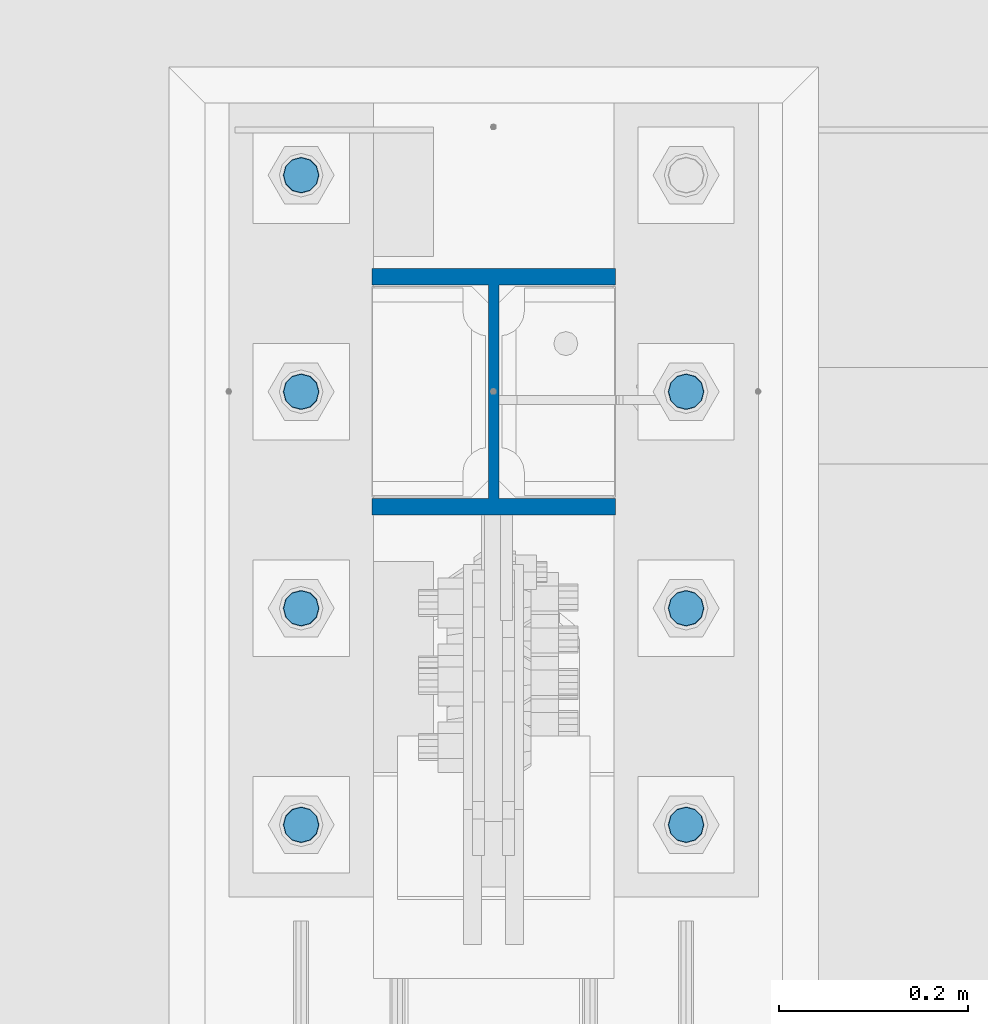
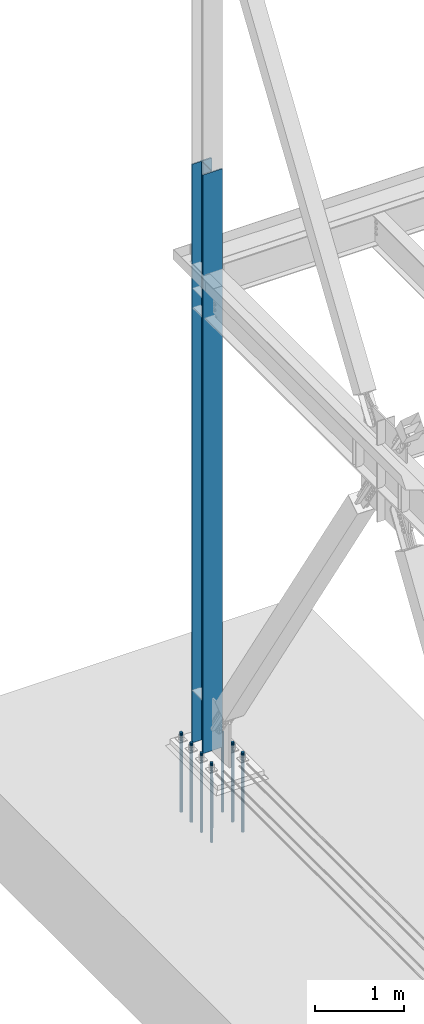
# One storey, part 1349 of 3843: 8 columns, 2 elements without a shape of their own.
"""IFC2X3 building model written with IfcOpenShell, lengths in millimetres."""

from ifc_helpers import new_model, si_unit, frame, origin_with_axes, place, context, subcontext, project, spatial, faceted_brep, material, type_object, element, aggregate, save


model = new_model("IFC2X3")

# Units and contexts
model_context = context("Model", 3, precision=1e-05, world=origin_with_axes())
body_context = subcontext(model_context, "Body", "Model", "MODEL_VIEW")
ifc_project = project(units=[si_unit("LENGTHUNIT", "METRE", prefix="MILLI"), si_unit("AREAUNIT", "SQUARE_METRE"), si_unit("VOLUMEUNIT", "CUBIC_METRE"), si_unit("MASSUNIT", "GRAM", prefix="KILO"), si_unit("TIMEUNIT", "SECOND"), si_unit("PLANEANGLEUNIT", "RADIAN"), si_unit("SOLIDANGLEUNIT", "STERADIAN"), si_unit("THERMODYNAMICTEMPERATUREUNIT", "DEGREE_CELSIUS"), si_unit("LUMINOUSINTENSITYUNIT", "LUMEN")], contexts=[model_context])

# Site, building, storey
site_placement = place(None, origin_with_axes())
site = spatial("IfcSite", under=ifc_project, at=site_placement, CompositionType="ELEMENT")
building_placement = place(site_placement, origin_with_axes())
building = spatial("IfcBuilding", under=site, at=building_placement, Name="Undefined", CompositionType="ELEMENT")
storey_placement = place(building_placement, origin_with_axes())
storey = spatial("IfcBuildingStorey", under=building, at=storey_placement, Name="Undefined", CompositionType="ELEMENT", Elevation=0.0)

# Assembly, column
assembly_1_placement = place(storey_placement, origin_with_axes())
assembly_1 = element("IfcElementAssembly", 1, at=assembly_1_placement, inside=storey, Name="COLUMN", AssemblyPlace="NOTDEFINED", PredefinedType="RIGID_FRAME")
ifc_material_1 = material(Name="STEEL/A992")
column_type_1 = type_object("IfcColumnType", Name="W10X60", PredefinedType="NOTDEFINED")
column_1_placement = place(assembly_1_placement, frame((0.0, 104559.1, 29718.0), z_axis=(0.0, 1.0, 0.0), x_axis=(0.0, 0.0, 1.0)))
column_1 = element("IfcColumn", 2, at=column_1_placement, type_object=column_type_1, material=ifc_material_1, Name="COLUMN", ObjectType="W10X60", context=body_context, shape_type="Brep", body=[
    faceted_brep([(101.599999999999, 128.587499999994, -130.174999999999), (101.599999999999, 128.587499999994, -112.712500000001), (8077.2, 128.5875, -112.712499999994), (8077.2, 128.5875, -130.175000000003), (101.599999999999, 5.55624999999418, -112.712500000001), (8077.2, 5.55625, -112.712499999994), (101.599999999999, 5.55624999999418, 112.712500000001), (8077.2, 5.55625, 112.712499999994), (101.599999999999, 128.587499999994, 112.712500000001), (8077.2, 128.5875, 112.712499999994), (101.599999999999, 128.587499999994, 130.174999999999), (8077.2, 128.5875, 130.175000000003), (101.599999999999, -128.587499999994, 130.174999999999), (8077.2, -128.5875, 130.175000000003), (101.599999999999, -128.587499999994, 112.712500000001), (8077.2, -128.5875, 112.712499999994), (101.599999999999, -5.55624999999418, 112.712500000001), (8077.2, -5.55625, 112.712499999994), (101.599999999999, -5.55624999999418, -112.712500000001), (8077.2, -5.55625, -112.712499999994), (101.599999999999, -128.587499999994, -112.712500000001), (8077.2, -128.5875, -112.712499999994), (101.599999999999, -128.587499999994, -130.174999999999), (8077.2, -128.5875, -130.175000000003)], [[[0, 1, 2, 3]], [[1, 4, 5, 2]], [[4, 6, 7, 5]], [[6, 8, 9, 7]], [[8, 10, 11, 9]], [[10, 12, 13, 11]], [[12, 14, 15, 13]], [[14, 16, 17, 15]], [[16, 18, 19, 17]], [[18, 20, 21, 19]], [[20, 22, 23, 21]], [[22, 0, 3, 23]], [[5, 7, 9, 11, 13, 15, 17, 19, 21, 23, 3, 2]], [[22, 20, 18, 16, 14, 12, 10, 8, 6, 4, 1, 0]]]),
])
aggregate(assembly_1, [column_1])

# Assembly, columns
assembly_2_placement = place(storey_placement, origin_with_axes())
assembly_2 = element("IfcElementAssembly", 3, at=assembly_2_placement, inside=storey, Name="TEMPLATE", AssemblyPlace="NOTDEFINED", PredefinedType="RIGID_FRAME")
ifc_material_2 = material(Name="Undefined/F1554-GR.55")
column_type_2 = type_object("IfcColumnType", PredefinedType="NOTDEFINED")
column_2_placement = place(assembly_2_placement, frame((-203.2, 104101.9, 29718.0), z_axis=(0.0, -1.0, 0.0), x_axis=(0.0, 0.0, -1.0)))
column_2 = element("IfcColumn", 4, at=column_2_placement, type_object=column_type_2, material=ifc_material_2, Name="ANCHOR_ROD", context=body_context, shape_type="Brep", body=[
    faceted_brep([(-209.549999999999, -16.0214699700155, 9.25), (-209.549999999999, -9.25, 16.0214699700118), (-209.549999999999, 0.0, 18.5), (-209.549999999999, 9.25, 16.0214699700118), (-209.549999999999, 16.0214699700155, 9.25), (-209.549999999999, 18.5, 0.0), (-209.549999999999, 16.0214699700155, -9.25), (-209.549999999999, 9.25, -16.0214699700118), (-209.549999999999, 0.0, -18.5), (-209.549999999999, -9.25, -16.0214699700118), (-209.549999999999, -16.0214699700155, -9.25), (-209.549999999999, -18.5, 0.0), (0.0, 18.5, 0.0), (0.0, 16.0214699700118, -9.25), (0.0, 9.25, -16.0214699700155), (0.0, 0.0, -18.5), (0.0, -9.25, -16.0214699700155), (0.0, -16.0214699700118, -9.25), (0.0, -18.5, 0.0), (0.0, -16.0214699700118, 9.25), (0.0, -9.25, 16.0214699700155), (0.0, 0.0, 18.5), (0.0, 9.25, 16.0214699700155), (0.0, 16.0214699700118, 9.25), (0.0, -16.4977839420972, 9.52500000000146), (0.0, -9.52500000000146, 16.4977839420972), (0.0, 0.0, 19.0499989999989), (0.0, 9.52500000000146, 16.4977839420972), (0.0, 16.4977839420972, 9.52500000000146), (0.0, 19.0500000000029, 0.0), (0.0, 16.4977839420972, -9.52500000000146), (0.0, 9.52500000000146, -16.4977839420972), (0.0, 0.0, -19.0499989999989), (0.0, -9.52500000000146, -16.4977839420972), (0.0, -16.4977839420972, -9.52500000000146), (0.0, -19.0500000000029, 0.0), (698.5, -19.0499999999993, 0.0), (698.5, -16.4977839420935, 9.52499999999418), (698.5, -9.52500000000146, 16.4977839420899), (698.5, 0.0, 19.0500000000029), (698.5, 9.52500000000146, 16.4977839420899), (698.5, 16.4977839420935, 9.52499999999418), (698.5, 19.0499999999993, 0.0), (698.5, 16.4977839420935, -9.52499999999418), (698.5, 9.52500000000146, -16.4977839420899), (698.5, 0.0, -19.0500000000029), (698.5, -9.52500000000146, -16.4977839420899), (698.5, -16.4977839420935, -9.52499999999418), (698.5, -9.25, 16.0214699700155), (698.5, 0.0, 18.5), (698.5, 9.25, 16.0214699700155), (698.5, 16.0214699700118, 9.25), (698.5, 18.5, 0.0), (698.5, 16.0214699700118, -9.25), (698.5, 9.25, -16.0214699700155), (698.5, 0.0, -18.5), (698.5, -9.25, -16.0214699700155), (698.5, -16.0214699700118, -9.25), (698.5, -18.5, 0.0), (698.5, -16.0214699700118, 9.25), (889.0, -9.25, -16.0214699700155), (889.0, 0.0, -18.5), (889.0, 9.25, -16.0214699700155), (889.0, 16.0214699700118, -9.25), (889.0, 18.5, 0.0), (889.0, 16.0214699700118, 9.25), (889.0, 9.25, 16.0214699700155), (889.0, 0.0, 18.5), (889.0, -9.25, 16.0214699700155), (889.0, -16.0214699700118, 9.25), (889.0, -18.5, 0.0), (889.0, -16.0214699700118, -9.25)], [[[0, 1, 2, 3, 4, 5, 6, 7, 8, 9, 10, 11]], [[6, 5, 12, 13]], [[7, 6, 13, 14]], [[8, 7, 14, 15]], [[9, 8, 15, 16]], [[10, 9, 16, 17]], [[11, 10, 17, 18]], [[0, 11, 18, 19]], [[1, 0, 19, 20]], [[2, 1, 20, 21]], [[3, 2, 21, 22]], [[4, 3, 22, 23]], [[5, 4, 23, 12]], [[24, 25, 26, 27, 28, 29, 30, 31, 32, 33, 34, 35], [22, 21, 20, 19, 18, 17, 16, 15, 14, 13, 12, 23]], [[24, 35, 36, 37]], [[25, 24, 37, 38]], [[26, 25, 38, 39]], [[27, 26, 39, 40]], [[28, 27, 40, 41]], [[29, 28, 41, 42]], [[30, 29, 42, 43]], [[31, 30, 43, 44]], [[32, 31, 44, 45]], [[33, 32, 45, 46]], [[34, 33, 46, 47]], [[35, 34, 47, 36]], [[46, 45, 44, 43, 42, 41, 40, 39, 38, 37, 36, 47], [48, 49, 50, 51, 52, 53, 54, 55, 56, 57, 58, 59]], [[60, 61, 62, 63, 64, 65, 66, 67, 68, 69, 70, 71]], [[68, 67, 49, 48]], [[69, 68, 48, 59]], [[70, 69, 59, 58]], [[71, 70, 58, 57]], [[60, 71, 57, 56]], [[61, 60, 56, 55]], [[62, 61, 55, 54]], [[63, 62, 54, 53]], [[64, 63, 53, 52]], [[65, 64, 52, 51]], [[66, 65, 51, 50]], [[67, 66, 50, 49]]]),
])
column_3_placement = place(assembly_2_placement, frame((203.2, 104101.9, 29718.0), z_axis=(0.0, 1.0, 0.0), x_axis=(0.0, 0.0, -1.0)))
column_3 = element("IfcColumn", 5, at=column_3_placement, type_object=column_type_2, material=ifc_material_2, Name="ANCHOR_ROD", context=body_context, shape_type="Brep", body=[
    faceted_brep([(-209.549999999999, -16.0214699700155, 9.25), (-209.549999999999, -9.25, 16.0214699700118), (-209.549999999999, 0.0, 18.5), (-209.549999999999, 9.25, 16.0214699700118), (-209.549999999999, 16.0214699700155, 9.25), (-209.549999999999, 18.5, 0.0), (-209.549999999999, 16.0214699700155, -9.25), (-209.549999999999, 9.25, -16.0214699700118), (-209.549999999999, 0.0, -18.5), (-209.549999999999, -9.25, -16.0214699700118), (-209.549999999999, -16.0214699700155, -9.25), (-209.549999999999, -18.5, 0.0), (0.0, 18.5, 0.0), (0.0, 16.0214699700118, -9.25), (0.0, 9.25, -16.0214699700155), (0.0, 0.0, -18.5), (0.0, -9.25, -16.0214699700155), (0.0, -16.0214699700118, -9.25), (0.0, -18.5, 0.0), (0.0, -16.0214699700118, 9.25), (0.0, -9.25, 16.0214699700155), (0.0, 0.0, 18.5), (0.0, 9.25, 16.0214699700155), (0.0, 16.0214699700118, 9.25), (0.0, -16.4977839420972, 9.52500000000146), (0.0, -9.52500000000146, 16.4977839420972), (0.0, 0.0, 19.0499989999989), (0.0, 9.52500000000146, 16.4977839420972), (0.0, 16.4977839420972, 9.52500000000146), (0.0, 19.0500000000029, 0.0), (0.0, 16.4977839420972, -9.52500000000146), (0.0, 9.52500000000146, -16.4977839420972), (0.0, 0.0, -19.0499989999989), (0.0, -9.52500000000146, -16.4977839420972), (0.0, -16.4977839420972, -9.52500000000146), (0.0, -19.0500000000029, 0.0), (698.5, -19.0499999999993, 0.0), (698.5, -16.4977839420935, 9.52499999999418), (698.5, -9.52500000000146, 16.4977839420899), (698.5, 0.0, 19.0500000000029), (698.5, 9.52500000000146, 16.4977839420899), (698.5, 16.4977839420935, 9.52499999999418), (698.5, 19.0499999999993, 0.0), (698.5, 16.4977839420935, -9.52499999999418), (698.5, 9.52500000000146, -16.4977839420899), (698.5, 0.0, -19.0500000000029), (698.5, -9.52500000000146, -16.4977839420899), (698.5, -16.4977839420935, -9.52499999999418), (698.5, -9.25, 16.0214699700155), (698.5, 0.0, 18.5), (698.5, 9.25, 16.0214699700155), (698.5, 16.0214699700118, 9.25), (698.5, 18.5, 0.0), (698.5, 16.0214699700118, -9.25), (698.5, 9.25, -16.0214699700155), (698.5, 0.0, -18.5), (698.5, -9.25, -16.0214699700155), (698.5, -16.0214699700118, -9.25), (698.5, -18.5, 0.0), (698.5, -16.0214699700118, 9.25), (889.0, -9.25, -16.0214699700155), (889.0, 0.0, -18.5), (889.0, 9.25, -16.0214699700155), (889.0, 16.0214699700118, -9.25), (889.0, 18.5, 0.0), (889.0, 16.0214699700118, 9.25), (889.0, 9.25, 16.0214699700155), (889.0, 0.0, 18.5), (889.0, -9.25, 16.0214699700155), (889.0, -16.0214699700118, 9.25), (889.0, -18.5, 0.0), (889.0, -16.0214699700118, -9.25)], [[[0, 1, 2, 3, 4, 5, 6, 7, 8, 9, 10, 11]], [[6, 5, 12, 13]], [[7, 6, 13, 14]], [[8, 7, 14, 15]], [[9, 8, 15, 16]], [[10, 9, 16, 17]], [[11, 10, 17, 18]], [[0, 11, 18, 19]], [[1, 0, 19, 20]], [[2, 1, 20, 21]], [[3, 2, 21, 22]], [[4, 3, 22, 23]], [[5, 4, 23, 12]], [[24, 25, 26, 27, 28, 29, 30, 31, 32, 33, 34, 35], [22, 21, 20, 19, 18, 17, 16, 15, 14, 13, 12, 23]], [[24, 35, 36, 37]], [[25, 24, 37, 38]], [[26, 25, 38, 39]], [[27, 26, 39, 40]], [[28, 27, 40, 41]], [[29, 28, 41, 42]], [[30, 29, 42, 43]], [[31, 30, 43, 44]], [[32, 31, 44, 45]], [[33, 32, 45, 46]], [[34, 33, 46, 47]], [[35, 34, 47, 36]], [[46, 45, 44, 43, 42, 41, 40, 39, 38, 37, 36, 47], [48, 49, 50, 51, 52, 53, 54, 55, 56, 57, 58, 59]], [[60, 61, 62, 63, 64, 65, 66, 67, 68, 69, 70, 71]], [[68, 67, 49, 48]], [[69, 68, 48, 59]], [[70, 69, 59, 58]], [[71, 70, 58, 57]], [[60, 71, 57, 56]], [[61, 60, 56, 55]], [[62, 61, 55, 54]], [[63, 62, 54, 53]], [[64, 63, 53, 52]], [[65, 64, 52, 51]], [[66, 65, 51, 50]], [[67, 66, 50, 49]]]),
])
column_4_placement = place(assembly_2_placement, frame((-203.2, 104330.5, 29718.0), z_axis=(0.0, -1.0, 0.0), x_axis=(0.0, 0.0, -1.0)))
column_4 = element("IfcColumn", 6, at=column_4_placement, type_object=column_type_2, material=ifc_material_2, Name="ANCHOR_ROD", context=body_context, shape_type="Brep", body=[
    faceted_brep([(-209.549999999999, -16.0214699700155, 9.25), (-209.549999999999, -9.25, 16.0214699700118), (-209.549999999999, 0.0, 18.5), (-209.549999999999, 9.25, 16.0214699700118), (-209.549999999999, 16.0214699700155, 9.25), (-209.549999999999, 18.5, 0.0), (-209.549999999999, 16.0214699700155, -9.25), (-209.549999999999, 9.25, -16.0214699700118), (-209.549999999999, 0.0, -18.5), (-209.549999999999, -9.25, -16.0214699700118), (-209.549999999999, -16.0214699700155, -9.25), (-209.549999999999, -18.5, 0.0), (0.0, 18.5, 0.0), (0.0, 16.0214699700118, -9.25), (0.0, 9.25, -16.0214699700155), (0.0, 0.0, -18.5), (0.0, -9.25, -16.0214699700155), (0.0, -16.0214699700118, -9.25), (0.0, -18.5, 0.0), (0.0, -16.0214699700118, 9.25), (0.0, -9.25, 16.0214699700155), (0.0, 0.0, 18.5), (0.0, 9.25, 16.0214699700155), (0.0, 16.0214699700118, 9.25), (0.0, -16.4977839420972, 9.52500000000146), (0.0, -9.52500000000146, 16.4977839420972), (0.0, 0.0, 19.0499989999989), (0.0, 9.52500000000146, 16.4977839420972), (0.0, 16.4977839420972, 9.52500000000146), (0.0, 19.0500000000029, 0.0), (0.0, 16.4977839420972, -9.52500000000146), (0.0, 9.52500000000146, -16.4977839420972), (0.0, 0.0, -19.0499989999989), (0.0, -9.52500000000146, -16.4977839420972), (0.0, -16.4977839420972, -9.52500000000146), (0.0, -19.0500000000029, 0.0), (698.5, -19.0499999999993, 0.0), (698.5, -16.4977839420935, 9.52499999999418), (698.5, -9.52500000000146, 16.4977839420899), (698.5, 0.0, 19.0500000000029), (698.5, 9.52500000000146, 16.4977839420899), (698.5, 16.4977839420935, 9.52499999999418), (698.5, 19.0499999999993, 0.0), (698.5, 16.4977839420935, -9.52499999999418), (698.5, 9.52500000000146, -16.4977839420899), (698.5, 0.0, -19.0500000000029), (698.5, -9.52500000000146, -16.4977839420899), (698.5, -16.4977839420935, -9.52499999999418), (698.5, -9.25, 16.0214699700155), (698.5, 0.0, 18.5), (698.5, 9.25, 16.0214699700155), (698.5, 16.0214699700118, 9.25), (698.5, 18.5, 0.0), (698.5, 16.0214699700118, -9.25), (698.5, 9.25, -16.0214699700155), (698.5, 0.0, -18.5), (698.5, -9.25, -16.0214699700155), (698.5, -16.0214699700118, -9.25), (698.5, -18.5, 0.0), (698.5, -16.0214699700118, 9.25), (889.0, -9.25, -16.0214699700155), (889.0, 0.0, -18.5), (889.0, 9.25, -16.0214699700155), (889.0, 16.0214699700118, -9.25), (889.0, 18.5, 0.0), (889.0, 16.0214699700118, 9.25), (889.0, 9.25, 16.0214699700155), (889.0, 0.0, 18.5), (889.0, -9.25, 16.0214699700155), (889.0, -16.0214699700118, 9.25), (889.0, -18.5, 0.0), (889.0, -16.0214699700118, -9.25)], [[[0, 1, 2, 3, 4, 5, 6, 7, 8, 9, 10, 11]], [[6, 5, 12, 13]], [[7, 6, 13, 14]], [[8, 7, 14, 15]], [[9, 8, 15, 16]], [[10, 9, 16, 17]], [[11, 10, 17, 18]], [[0, 11, 18, 19]], [[1, 0, 19, 20]], [[2, 1, 20, 21]], [[3, 2, 21, 22]], [[4, 3, 22, 23]], [[5, 4, 23, 12]], [[24, 25, 26, 27, 28, 29, 30, 31, 32, 33, 34, 35], [22, 21, 20, 19, 18, 17, 16, 15, 14, 13, 12, 23]], [[24, 35, 36, 37]], [[25, 24, 37, 38]], [[26, 25, 38, 39]], [[27, 26, 39, 40]], [[28, 27, 40, 41]], [[29, 28, 41, 42]], [[30, 29, 42, 43]], [[31, 30, 43, 44]], [[32, 31, 44, 45]], [[33, 32, 45, 46]], [[34, 33, 46, 47]], [[35, 34, 47, 36]], [[46, 45, 44, 43, 42, 41, 40, 39, 38, 37, 36, 47], [48, 49, 50, 51, 52, 53, 54, 55, 56, 57, 58, 59]], [[60, 61, 62, 63, 64, 65, 66, 67, 68, 69, 70, 71]], [[68, 67, 49, 48]], [[69, 68, 48, 59]], [[70, 69, 59, 58]], [[71, 70, 58, 57]], [[60, 71, 57, 56]], [[61, 60, 56, 55]], [[62, 61, 55, 54]], [[63, 62, 54, 53]], [[64, 63, 53, 52]], [[65, 64, 52, 51]], [[66, 65, 51, 50]], [[67, 66, 50, 49]]]),
])
column_5_placement = place(assembly_2_placement, frame((203.2, 104330.5, 29718.0), z_axis=(0.0, 1.0, 0.0), x_axis=(0.0, 0.0, -1.0)))
column_5 = element("IfcColumn", 7, at=column_5_placement, type_object=column_type_2, material=ifc_material_2, Name="ANCHOR_ROD", context=body_context, shape_type="Brep", body=[
    faceted_brep([(-209.549999999999, -16.0214699700155, 9.25), (-209.549999999999, -9.25, 16.0214699700118), (-209.549999999999, 0.0, 18.5), (-209.549999999999, 9.25, 16.0214699700118), (-209.549999999999, 16.0214699700155, 9.25), (-209.549999999999, 18.5, 0.0), (-209.549999999999, 16.0214699700155, -9.25), (-209.549999999999, 9.25, -16.0214699700118), (-209.549999999999, 0.0, -18.5), (-209.549999999999, -9.25, -16.0214699700118), (-209.549999999999, -16.0214699700155, -9.25), (-209.549999999999, -18.5, 0.0), (0.0, 18.5, 0.0), (0.0, 16.0214699700118, -9.25), (0.0, 9.25, -16.0214699700155), (0.0, 0.0, -18.5), (0.0, -9.25, -16.0214699700155), (0.0, -16.0214699700118, -9.25), (0.0, -18.5, 0.0), (0.0, -16.0214699700118, 9.25), (0.0, -9.25, 16.0214699700155), (0.0, 0.0, 18.5), (0.0, 9.25, 16.0214699700155), (0.0, 16.0214699700118, 9.25), (0.0, -16.4977839420972, 9.52500000000146), (0.0, -9.52500000000146, 16.4977839420972), (0.0, 0.0, 19.0499989999989), (0.0, 9.52500000000146, 16.4977839420972), (0.0, 16.4977839420972, 9.52500000000146), (0.0, 19.0500000000029, 0.0), (0.0, 16.4977839420972, -9.52500000000146), (0.0, 9.52500000000146, -16.4977839420972), (0.0, 0.0, -19.0499989999989), (0.0, -9.52500000000146, -16.4977839420972), (0.0, -16.4977839420972, -9.52500000000146), (0.0, -19.0500000000029, 0.0), (698.5, -19.0499999999993, 0.0), (698.5, -16.4977839420935, 9.52499999999418), (698.5, -9.52500000000146, 16.4977839420899), (698.5, 0.0, 19.0500000000029), (698.5, 9.52500000000146, 16.4977839420899), (698.5, 16.4977839420935, 9.52499999999418), (698.5, 19.0499999999993, 0.0), (698.5, 16.4977839420935, -9.52499999999418), (698.5, 9.52500000000146, -16.4977839420899), (698.5, 0.0, -19.0500000000029), (698.5, -9.52500000000146, -16.4977839420899), (698.5, -16.4977839420935, -9.52499999999418), (698.5, -9.25, 16.0214699700155), (698.5, 0.0, 18.5), (698.5, 9.25, 16.0214699700155), (698.5, 16.0214699700118, 9.25), (698.5, 18.5, 0.0), (698.5, 16.0214699700118, -9.25), (698.5, 9.25, -16.0214699700155), (698.5, 0.0, -18.5), (698.5, -9.25, -16.0214699700155), (698.5, -16.0214699700118, -9.25), (698.5, -18.5, 0.0), (698.5, -16.0214699700118, 9.25), (889.0, -9.25, -16.0214699700155), (889.0, 0.0, -18.5), (889.0, 9.25, -16.0214699700155), (889.0, 16.0214699700118, -9.25), (889.0, 18.5, 0.0), (889.0, 16.0214699700118, 9.25), (889.0, 9.25, 16.0214699700155), (889.0, 0.0, 18.5), (889.0, -9.25, 16.0214699700155), (889.0, -16.0214699700118, 9.25), (889.0, -18.5, 0.0), (889.0, -16.0214699700118, -9.25)], [[[0, 1, 2, 3, 4, 5, 6, 7, 8, 9, 10, 11]], [[6, 5, 12, 13]], [[7, 6, 13, 14]], [[8, 7, 14, 15]], [[9, 8, 15, 16]], [[10, 9, 16, 17]], [[11, 10, 17, 18]], [[0, 11, 18, 19]], [[1, 0, 19, 20]], [[2, 1, 20, 21]], [[3, 2, 21, 22]], [[4, 3, 22, 23]], [[5, 4, 23, 12]], [[24, 25, 26, 27, 28, 29, 30, 31, 32, 33, 34, 35], [22, 21, 20, 19, 18, 17, 16, 15, 14, 13, 12, 23]], [[24, 35, 36, 37]], [[25, 24, 37, 38]], [[26, 25, 38, 39]], [[27, 26, 39, 40]], [[28, 27, 40, 41]], [[29, 28, 41, 42]], [[30, 29, 42, 43]], [[31, 30, 43, 44]], [[32, 31, 44, 45]], [[33, 32, 45, 46]], [[34, 33, 46, 47]], [[35, 34, 47, 36]], [[46, 45, 44, 43, 42, 41, 40, 39, 38, 37, 36, 47], [48, 49, 50, 51, 52, 53, 54, 55, 56, 57, 58, 59]], [[60, 61, 62, 63, 64, 65, 66, 67, 68, 69, 70, 71]], [[68, 67, 49, 48]], [[69, 68, 48, 59]], [[70, 69, 59, 58]], [[71, 70, 58, 57]], [[60, 71, 57, 56]], [[61, 60, 56, 55]], [[62, 61, 55, 54]], [[63, 62, 54, 53]], [[64, 63, 53, 52]], [[65, 64, 52, 51]], [[66, 65, 51, 50]], [[67, 66, 50, 49]]]),
])
column_6_placement = place(assembly_2_placement, frame((-203.2, 104559.1, 29718.0), z_axis=(0.0, -1.0, 0.0), x_axis=(0.0, 0.0, -1.0)))
column_6 = element("IfcColumn", 8, at=column_6_placement, type_object=column_type_2, material=ifc_material_2, Name="ANCHOR_ROD", context=body_context, shape_type="Brep", body=[
    faceted_brep([(-209.549999999999, -16.0214699700155, 9.25), (-209.549999999999, -9.25, 16.0214699700118), (-209.549999999999, 0.0, 18.5), (-209.549999999999, 9.25, 16.0214699700118), (-209.549999999999, 16.0214699700155, 9.25), (-209.549999999999, 18.5, 0.0), (-209.549999999999, 16.0214699700155, -9.25), (-209.549999999999, 9.25, -16.0214699700118), (-209.549999999999, 0.0, -18.5), (-209.549999999999, -9.25, -16.0214699700118), (-209.549999999999, -16.0214699700155, -9.25), (-209.549999999999, -18.5, 0.0), (0.0, 18.5, 0.0), (0.0, 16.0214699700118, -9.25), (0.0, 9.25, -16.0214699700155), (0.0, 0.0, -18.5), (0.0, -9.25, -16.0214699700155), (0.0, -16.0214699700118, -9.25), (0.0, -18.5, 0.0), (0.0, -16.0214699700118, 9.25), (0.0, -9.25, 16.0214699700155), (0.0, 0.0, 18.5), (0.0, 9.25, 16.0214699700155), (0.0, 16.0214699700118, 9.25), (0.0, -16.4977839420972, 9.52500000000146), (0.0, -9.52500000000146, 16.4977839420972), (0.0, 0.0, 19.0499989999989), (0.0, 9.52500000000146, 16.4977839420972), (0.0, 16.4977839420972, 9.52500000000146), (0.0, 19.0500000000029, 0.0), (0.0, 16.4977839420972, -9.52500000000146), (0.0, 9.52500000000146, -16.4977839420972), (0.0, 0.0, -19.0499989999989), (0.0, -9.52500000000146, -16.4977839420972), (0.0, -16.4977839420972, -9.52500000000146), (0.0, -19.0500000000029, 0.0), (698.5, -19.0499999999993, 0.0), (698.5, -16.4977839420935, 9.52499999999418), (698.5, -9.52500000000146, 16.4977839420899), (698.5, 0.0, 19.0500000000029), (698.5, 9.52500000000146, 16.4977839420899), (698.5, 16.4977839420935, 9.52499999999418), (698.5, 19.0499999999993, 0.0), (698.5, 16.4977839420935, -9.52499999999418), (698.5, 9.52500000000146, -16.4977839420899), (698.5, 0.0, -19.0500000000029), (698.5, -9.52500000000146, -16.4977839420899), (698.5, -16.4977839420935, -9.52499999999418), (698.5, -9.25, 16.0214699700155), (698.5, 0.0, 18.5), (698.5, 9.25, 16.0214699700155), (698.5, 16.0214699700118, 9.25), (698.5, 18.5, 0.0), (698.5, 16.0214699700118, -9.25), (698.5, 9.25, -16.0214699700155), (698.5, 0.0, -18.5), (698.5, -9.25, -16.0214699700155), (698.5, -16.0214699700118, -9.25), (698.5, -18.5, 0.0), (698.5, -16.0214699700118, 9.25), (889.0, -9.25, -16.0214699700155), (889.0, 0.0, -18.5), (889.0, 9.25, -16.0214699700155), (889.0, 16.0214699700118, -9.25), (889.0, 18.5, 0.0), (889.0, 16.0214699700118, 9.25), (889.0, 9.25, 16.0214699700155), (889.0, 0.0, 18.5), (889.0, -9.25, 16.0214699700155), (889.0, -16.0214699700118, 9.25), (889.0, -18.5, 0.0), (889.0, -16.0214699700118, -9.25)], [[[0, 1, 2, 3, 4, 5, 6, 7, 8, 9, 10, 11]], [[6, 5, 12, 13]], [[7, 6, 13, 14]], [[8, 7, 14, 15]], [[9, 8, 15, 16]], [[10, 9, 16, 17]], [[11, 10, 17, 18]], [[0, 11, 18, 19]], [[1, 0, 19, 20]], [[2, 1, 20, 21]], [[3, 2, 21, 22]], [[4, 3, 22, 23]], [[5, 4, 23, 12]], [[24, 25, 26, 27, 28, 29, 30, 31, 32, 33, 34, 35], [22, 21, 20, 19, 18, 17, 16, 15, 14, 13, 12, 23]], [[24, 35, 36, 37]], [[25, 24, 37, 38]], [[26, 25, 38, 39]], [[27, 26, 39, 40]], [[28, 27, 40, 41]], [[29, 28, 41, 42]], [[30, 29, 42, 43]], [[31, 30, 43, 44]], [[32, 31, 44, 45]], [[33, 32, 45, 46]], [[34, 33, 46, 47]], [[35, 34, 47, 36]], [[46, 45, 44, 43, 42, 41, 40, 39, 38, 37, 36, 47], [48, 49, 50, 51, 52, 53, 54, 55, 56, 57, 58, 59]], [[60, 61, 62, 63, 64, 65, 66, 67, 68, 69, 70, 71]], [[68, 67, 49, 48]], [[69, 68, 48, 59]], [[70, 69, 59, 58]], [[71, 70, 58, 57]], [[60, 71, 57, 56]], [[61, 60, 56, 55]], [[62, 61, 55, 54]], [[63, 62, 54, 53]], [[64, 63, 53, 52]], [[65, 64, 52, 51]], [[66, 65, 51, 50]], [[67, 66, 50, 49]]]),
])
column_7_placement = place(assembly_2_placement, frame((203.2, 104559.1, 29718.0), z_axis=(0.0, 1.0, 0.0), x_axis=(0.0, 0.0, -1.0)))
column_7 = element("IfcColumn", 9, at=column_7_placement, type_object=column_type_2, material=ifc_material_2, Name="ANCHOR_ROD", context=body_context, shape_type="Brep", body=[
    faceted_brep([(-209.549999999999, -16.0214699700155, 9.25), (-209.549999999999, -9.25, 16.0214699700118), (-209.549999999999, 0.0, 18.5), (-209.549999999999, 9.25, 16.0214699700118), (-209.549999999999, 16.0214699700155, 9.25), (-209.549999999999, 18.5, 0.0), (-209.549999999999, 16.0214699700155, -9.25), (-209.549999999999, 9.25, -16.0214699700118), (-209.549999999999, 0.0, -18.5), (-209.549999999999, -9.25, -16.0214699700118), (-209.549999999999, -16.0214699700155, -9.25), (-209.549999999999, -18.5, 0.0), (0.0, 18.5, 0.0), (0.0, 16.0214699700118, -9.25), (0.0, 9.25, -16.0214699700155), (0.0, 0.0, -18.5), (0.0, -9.25, -16.0214699700155), (0.0, -16.0214699700118, -9.25), (0.0, -18.5, 0.0), (0.0, -16.0214699700118, 9.25), (0.0, -9.25, 16.0214699700155), (0.0, 0.0, 18.5), (0.0, 9.25, 16.0214699700155), (0.0, 16.0214699700118, 9.25), (0.0, -16.4977839420972, 9.52500000000146), (0.0, -9.52500000000146, 16.4977839420972), (0.0, 0.0, 19.0499989999989), (0.0, 9.52500000000146, 16.4977839420972), (0.0, 16.4977839420972, 9.52500000000146), (0.0, 19.0500000000029, 0.0), (0.0, 16.4977839420972, -9.52500000000146), (0.0, 9.52500000000146, -16.4977839420972), (0.0, 0.0, -19.0499989999989), (0.0, -9.52500000000146, -16.4977839420972), (0.0, -16.4977839420972, -9.52500000000146), (0.0, -19.0500000000029, 0.0), (698.5, -19.0499999999993, 0.0), (698.5, -16.4977839420935, 9.52499999999418), (698.5, -9.52500000000146, 16.4977839420899), (698.5, 0.0, 19.0500000000029), (698.5, 9.52500000000146, 16.4977839420899), (698.5, 16.4977839420935, 9.52499999999418), (698.5, 19.0499999999993, 0.0), (698.5, 16.4977839420935, -9.52499999999418), (698.5, 9.52500000000146, -16.4977839420899), (698.5, 0.0, -19.0500000000029), (698.5, -9.52500000000146, -16.4977839420899), (698.5, -16.4977839420935, -9.52499999999418), (698.5, -9.25, 16.0214699700155), (698.5, 0.0, 18.5), (698.5, 9.25, 16.0214699700155), (698.5, 16.0214699700118, 9.25), (698.5, 18.5, 0.0), (698.5, 16.0214699700118, -9.25), (698.5, 9.25, -16.0214699700155), (698.5, 0.0, -18.5), (698.5, -9.25, -16.0214699700155), (698.5, -16.0214699700118, -9.25), (698.5, -18.5, 0.0), (698.5, -16.0214699700118, 9.25), (889.0, -9.25, -16.0214699700155), (889.0, 0.0, -18.5), (889.0, 9.25, -16.0214699700155), (889.0, 16.0214699700118, -9.25), (889.0, 18.5, 0.0), (889.0, 16.0214699700118, 9.25), (889.0, 9.25, 16.0214699700155), (889.0, 0.0, 18.5), (889.0, -9.25, 16.0214699700155), (889.0, -16.0214699700118, 9.25), (889.0, -18.5, 0.0), (889.0, -16.0214699700118, -9.25)], [[[0, 1, 2, 3, 4, 5, 6, 7, 8, 9, 10, 11]], [[6, 5, 12, 13]], [[7, 6, 13, 14]], [[8, 7, 14, 15]], [[9, 8, 15, 16]], [[10, 9, 16, 17]], [[11, 10, 17, 18]], [[0, 11, 18, 19]], [[1, 0, 19, 20]], [[2, 1, 20, 21]], [[3, 2, 21, 22]], [[4, 3, 22, 23]], [[5, 4, 23, 12]], [[24, 25, 26, 27, 28, 29, 30, 31, 32, 33, 34, 35], [22, 21, 20, 19, 18, 17, 16, 15, 14, 13, 12, 23]], [[24, 35, 36, 37]], [[25, 24, 37, 38]], [[26, 25, 38, 39]], [[27, 26, 39, 40]], [[28, 27, 40, 41]], [[29, 28, 41, 42]], [[30, 29, 42, 43]], [[31, 30, 43, 44]], [[32, 31, 44, 45]], [[33, 32, 45, 46]], [[34, 33, 46, 47]], [[35, 34, 47, 36]], [[46, 45, 44, 43, 42, 41, 40, 39, 38, 37, 36, 47], [48, 49, 50, 51, 52, 53, 54, 55, 56, 57, 58, 59]], [[60, 61, 62, 63, 64, 65, 66, 67, 68, 69, 70, 71]], [[68, 67, 49, 48]], [[69, 68, 48, 59]], [[70, 69, 59, 58]], [[71, 70, 58, 57]], [[60, 71, 57, 56]], [[61, 60, 56, 55]], [[62, 61, 55, 54]], [[63, 62, 54, 53]], [[64, 63, 53, 52]], [[65, 64, 52, 51]], [[66, 65, 51, 50]], [[67, 66, 50, 49]]]),
])
column_8_placement = place(assembly_2_placement, frame((-203.2, 104787.7, 29718.0), z_axis=(0.0, -1.0, 0.0), x_axis=(0.0, 0.0, -1.0)))
column_8 = element("IfcColumn", 10, at=column_8_placement, type_object=column_type_2, material=ifc_material_2, Name="ANCHOR_ROD", context=body_context, shape_type="Brep", body=[
    faceted_brep([(-209.549999999999, -16.0214699700155, 9.25), (-209.549999999999, -9.25, 16.0214699700118), (-209.549999999999, 0.0, 18.5), (-209.549999999999, 9.25, 16.0214699700118), (-209.549999999999, 16.0214699700155, 9.25), (-209.549999999999, 18.5, 0.0), (-209.549999999999, 16.0214699700155, -9.25), (-209.549999999999, 9.25, -16.0214699700118), (-209.549999999999, 0.0, -18.5), (-209.549999999999, -9.25, -16.0214699700118), (-209.549999999999, -16.0214699700155, -9.25), (-209.549999999999, -18.5, 0.0), (0.0, 18.5, 0.0), (0.0, 16.0214699700118, -9.25), (0.0, 9.25, -16.0214699700155), (0.0, 0.0, -18.5), (0.0, -9.25, -16.0214699700155), (0.0, -16.0214699700118, -9.25), (0.0, -18.5, 0.0), (0.0, -16.0214699700118, 9.25), (0.0, -9.25, 16.0214699700155), (0.0, 0.0, 18.5), (0.0, 9.25, 16.0214699700155), (0.0, 16.0214699700118, 9.25), (0.0, -16.4977839420972, 9.52500000000146), (0.0, -9.52500000000146, 16.4977839420972), (0.0, 0.0, 19.0499989999989), (0.0, 9.52500000000146, 16.4977839420972), (0.0, 16.4977839420972, 9.52500000000146), (0.0, 19.0500000000029, 0.0), (0.0, 16.4977839420972, -9.52500000000146), (0.0, 9.52500000000146, -16.4977839420972), (0.0, 0.0, -19.0499989999989), (0.0, -9.52500000000146, -16.4977839420972), (0.0, -16.4977839420972, -9.52500000000146), (0.0, -19.0500000000029, 0.0), (698.5, -19.0499999999993, 0.0), (698.5, -16.4977839420935, 9.52499999999418), (698.5, -9.52500000000146, 16.4977839420899), (698.5, 0.0, 19.0500000000029), (698.5, 9.52500000000146, 16.4977839420899), (698.5, 16.4977839420935, 9.52499999999418), (698.5, 19.0499999999993, 0.0), (698.5, 16.4977839420935, -9.52499999999418), (698.5, 9.52500000000146, -16.4977839420899), (698.5, 0.0, -19.0500000000029), (698.5, -9.52500000000146, -16.4977839420899), (698.5, -16.4977839420935, -9.52499999999418), (698.5, -9.25, 16.0214699700155), (698.5, 0.0, 18.5), (698.5, 9.25, 16.0214699700155), (698.5, 16.0214699700118, 9.25), (698.5, 18.5, 0.0), (698.5, 16.0214699700118, -9.25), (698.5, 9.25, -16.0214699700155), (698.5, 0.0, -18.5), (698.5, -9.25, -16.0214699700155), (698.5, -16.0214699700118, -9.25), (698.5, -18.5, 0.0), (698.5, -16.0214699700118, 9.25), (889.0, -9.25, -16.0214699700155), (889.0, 0.0, -18.5), (889.0, 9.25, -16.0214699700155), (889.0, 16.0214699700118, -9.25), (889.0, 18.5, 0.0), (889.0, 16.0214699700118, 9.25), (889.0, 9.25, 16.0214699700155), (889.0, 0.0, 18.5), (889.0, -9.25, 16.0214699700155), (889.0, -16.0214699700118, 9.25), (889.0, -18.5, 0.0), (889.0, -16.0214699700118, -9.25)], [[[0, 1, 2, 3, 4, 5, 6, 7, 8, 9, 10, 11]], [[6, 5, 12, 13]], [[7, 6, 13, 14]], [[8, 7, 14, 15]], [[9, 8, 15, 16]], [[10, 9, 16, 17]], [[11, 10, 17, 18]], [[0, 11, 18, 19]], [[1, 0, 19, 20]], [[2, 1, 20, 21]], [[3, 2, 21, 22]], [[4, 3, 22, 23]], [[5, 4, 23, 12]], [[24, 25, 26, 27, 28, 29, 30, 31, 32, 33, 34, 35], [22, 21, 20, 19, 18, 17, 16, 15, 14, 13, 12, 23]], [[24, 35, 36, 37]], [[25, 24, 37, 38]], [[26, 25, 38, 39]], [[27, 26, 39, 40]], [[28, 27, 40, 41]], [[29, 28, 41, 42]], [[30, 29, 42, 43]], [[31, 30, 43, 44]], [[32, 31, 44, 45]], [[33, 32, 45, 46]], [[34, 33, 46, 47]], [[35, 34, 47, 36]], [[46, 45, 44, 43, 42, 41, 40, 39, 38, 37, 36, 47], [48, 49, 50, 51, 52, 53, 54, 55, 56, 57, 58, 59]], [[60, 61, 62, 63, 64, 65, 66, 67, 68, 69, 70, 71]], [[68, 67, 49, 48]], [[69, 68, 48, 59]], [[70, 69, 59, 58]], [[71, 70, 58, 57]], [[60, 71, 57, 56]], [[61, 60, 56, 55]], [[62, 61, 55, 54]], [[63, 62, 54, 53]], [[64, 63, 53, 52]], [[65, 64, 52, 51]], [[66, 65, 51, 50]], [[67, 66, 50, 49]]]),
])
aggregate(assembly_2, [column_2, column_3, column_4, column_5, column_6, column_7, column_8])

save(model, "model.ifc")
